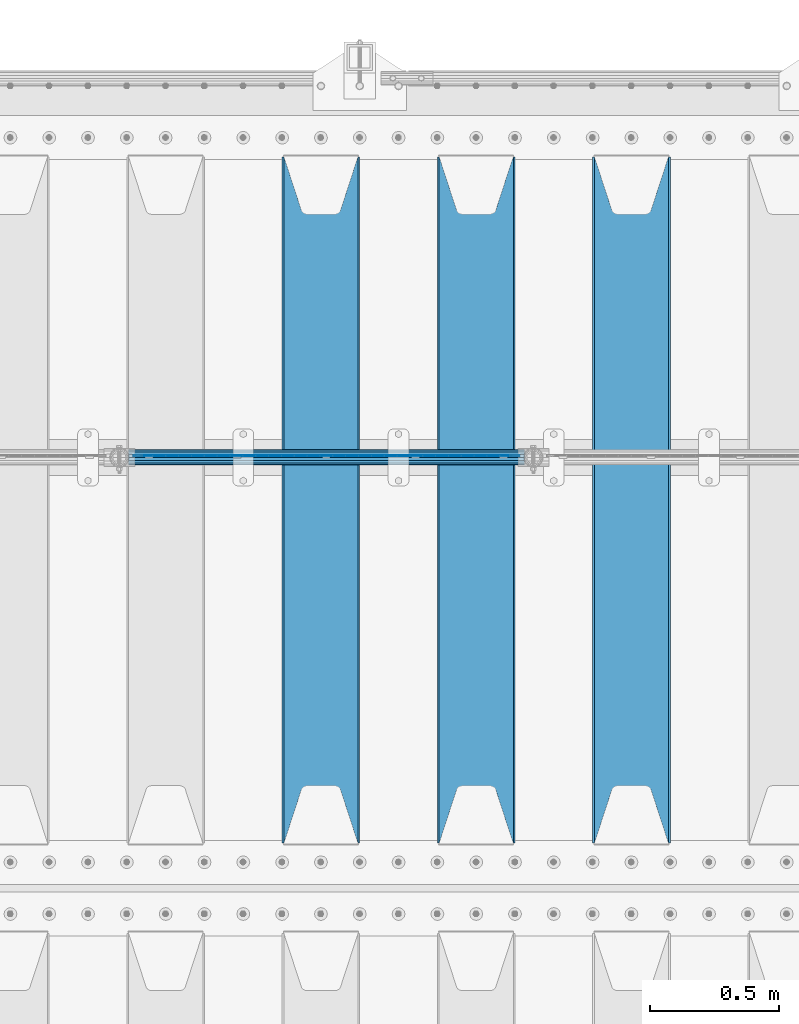
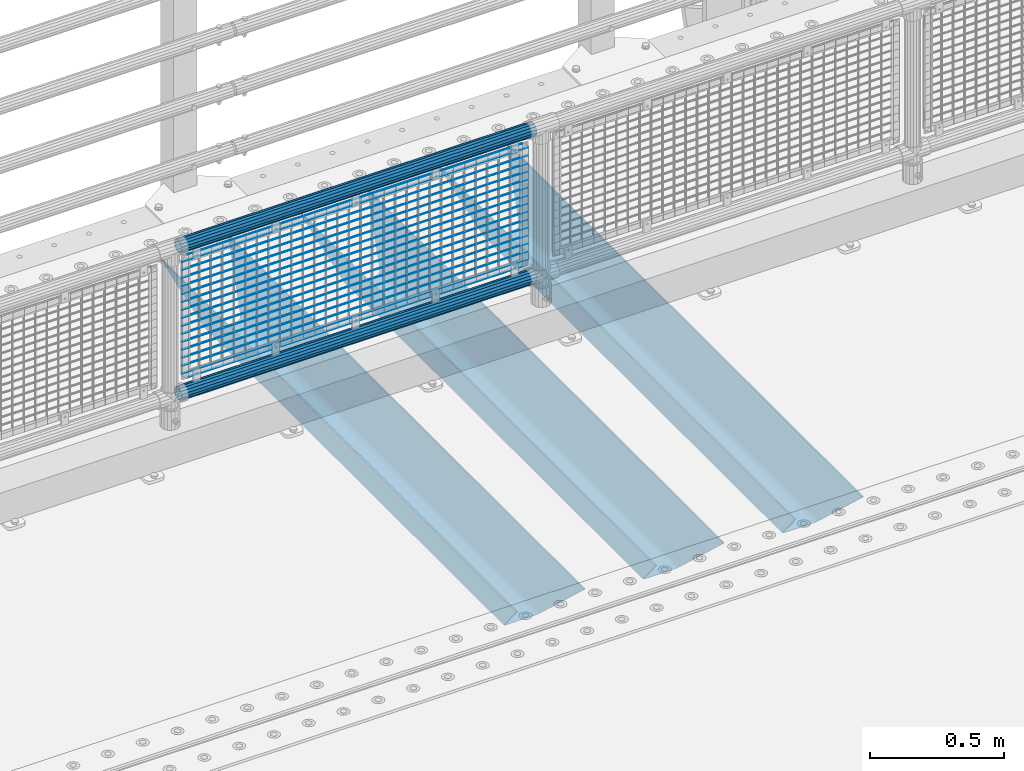
# One storey, part 126 of 247: 22 beams.
"""IFC2X3 building model written with IfcOpenShell, lengths in millimetres."""

from ifc_helpers import new_model, si_unit, frame, origin_with_axes, place, context, subcontext, project, spatial, faceted_brep, material, type_object, element, save


model = new_model("IFC2X3")

# Units and contexts
model_context = context("Model", 3, precision=1e-05, world=origin_with_axes())
body_context = subcontext(model_context, "Body", "Model", "MODEL_VIEW")
ifc_project = project(units=[si_unit("LENGTHUNIT", "METRE", prefix="MILLI"), si_unit("AREAUNIT", "SQUARE_METRE"), si_unit("VOLUMEUNIT", "CUBIC_METRE"), si_unit("MASSUNIT", "GRAM", prefix="KILO"), si_unit("TIMEUNIT", "SECOND"), si_unit("PLANEANGLEUNIT", "RADIAN"), si_unit("SOLIDANGLEUNIT", "STERADIAN"), si_unit("THERMODYNAMICTEMPERATUREUNIT", "DEGREE_CELSIUS"), si_unit("LUMINOUSINTENSITYUNIT", "LUMEN")], contexts=[model_context])

# Site, building, storey
site_placement = place(None, origin_with_axes())
site = spatial("IfcSite", under=ifc_project, at=site_placement, CompositionType="ELEMENT")
building_placement = place(site_placement, origin_with_axes())
building = spatial("IfcBuilding", under=site, at=building_placement, Name="Standard", CompositionType="ELEMENT")
storey_placement = place(building_placement, origin_with_axes())
storey = spatial("IfcBuildingStorey", under=building, at=storey_placement, Name="Undefined", CompositionType="ELEMENT", Elevation=0.0)

# Beams
ifc_material_1 = material(Name="STEEL/S355N")
beam_type_1 = type_object("IfcBeamType", PredefinedType="NOTDEFINED")
beam_1_placement = place(storey_placement, frame((10600.0, 6175.0, -115.0), z_axis=(0.0, 0.0, 1.0), x_axis=(0.0, 1.0, 0.0)))
element("IfcBeam", 1, at=beam_1_placement, inside=storey, type_object=beam_type_1, material=ifc_material_1, context=body_context, shape_type="Brep", body=[
    faceted_brep([(0.0, 150.0, 115.0), (0.0, 143.689999999999, 115.0), (2650.00000000297, 143.689999999999, 115.0), (2650.00000000297, 150.0, 115.0), (2650.00000000297, 142.059565218402, 110.0000000031), (2650.00000000297, 148.369565218403, 110.0000000031), (2441.90079219208, -80.1103600731112, -98.0992078077845), (2437.7588105432, -77.5672621345584, -102.241189456673), (2434.06523489746, -74.4080125315522, -105.934765102404), (2430.91086095089, -70.710272125576, -109.089139048974), (2428.37322971128, -66.5649389910068, -111.626770288588), (2426.51472138054, -62.0739139532889, -113.485278619323), (2425.38102192091, -57.3475956567672, -114.618978078955), (2424.99999999987, -52.5021667386536, -115.0), (2424.99999999987, 52.5021667386536, -115.0), (2425.38102192091, 57.3475956567672, -114.618978078955), (2426.51472138054, 62.0739139532889, -113.485278619323), (2428.37322971128, 66.5649389910068, -111.626770288588), (2430.91086095089, 70.710272125576, -109.089139048974), (2434.06523489746, 74.4080125315522, -105.934765102404), (2437.7588105432, 77.5672621345584, -102.241189456673), (2441.90079219208, 80.1103600731112, -98.0992078077846), (2446.38936140511, 81.9747917625791, -93.6106385947584), (2448.24948500409, 76.2713538057251, -91.7505149957729), (2444.62967112262, 74.76777986261, -95.3703288772456), (2441.28936334126, 72.7168944282894, -98.710636658607), (2438.31067330438, 70.1691124903846, -101.689326695487), (2435.76682334747, 67.1870637758839, -104.233176652398), (2433.72034654133, 63.8440531834895, -106.279653458539), (2432.22154950041, 60.222258798236, -107.778450499454), (2431.30727574265, 56.4107117849089, -108.692724257221), (2430.99999999987, 52.5031078186876, -109.0), (2430.99999999987, -52.5031078186876, -109.0), (2431.30727574265, -56.4107117849089, -108.692724257221), (2432.22154950041, -60.222258798236, -107.778450499454), (2433.72034654133, -63.8440531834895, -106.279653458539), (2435.76682334747, -67.1870637758839, -104.233176652398), (2438.31067330438, -70.1691124903846, -101.689326695487), (2441.28936334126, -72.7168944282894, -98.7106366586071), (2444.62967112262, -74.76777986261, -95.3703288772457), (2448.24948500409, -76.2713538057251, -91.7505149957729), (2650.00000000297, -142.059565218402, 110.0000000031), (2650.00000000297, -148.369565218403, 110.0000000031), (2446.38936140511, -81.9747917625791, -93.6106385947584), (2650.00000000297, -143.689999999999, 115.0), (2650.00000000297, -150.0, 115.0), (0.0, -143.689999999999, 115.0), (0.0, -150.0, 115.0), (0.0, -148.369565218261, 110.000000002663), (203.610638597422, -81.9747917625791, -93.6106385947584), (208.099207810448, -80.1103600731112, -98.0992078077845), (212.241189459336, -77.5672621345584, -102.241189456673), (215.934765105068, -74.4080125315522, -105.934765102404), (219.089139051637, -70.710272125576, -109.089139048974), (221.626770291251, -66.5649389910068, -111.626770288588), (223.485278621985, -62.0739139532889, -113.485278619323), (224.618978081617, -57.3475956567672, -114.618978078955), (225.000000002663, -52.5021667386536, -115.0), (225.000000002663, 52.5021667386536, -115.0), (224.618978081617, 57.3475956567672, -114.618978078955), (223.485278621985, 62.0739139532889, -113.485278619323), (221.626770291251, 66.5649389910068, -111.626770288588), (219.089139051637, 70.710272125576, -109.089139048974), (215.934765105068, 74.4080125315522, -105.934765102404), (212.241189459336, 77.5672621345584, -102.241189456673), (208.099207810448, 80.1103600731112, -98.0992078077846), (203.610638597422, 81.9747917625791, -93.6106385947584), (0.0, 148.369565218261, 110.000000002663), (0.0, 142.05956521826, 110.000000002663), (201.750514998436, 76.2713538057251, -91.7505149957729), (205.370328879908, 74.76777986261, -95.3703288772456), (208.710636661271, 72.7168944282894, -98.710636658607), (211.68932669815, 70.1691124903846, -101.689326695487), (214.233176655061, 67.1870637758839, -104.233176652398), (216.279653461202, 63.8440531834895, -106.279653458539), (217.778450502117, 60.222258798236, -107.778450499454), (218.692724259885, 56.4107117849089, -108.692724257221), (219.000000002663, 52.5031078186876, -109.0), (219.000000002663, -52.5031078186876, -109.0), (218.692724259885, -56.4107117849089, -108.692724257221), (217.778450502117, -60.222258798236, -107.778450499454), (216.279653461202, -63.8440531834895, -106.279653458539), (214.233176655061, -67.1870637758839, -104.233176652398), (211.68932669815, -70.1691124903846, -101.689326695487), (208.710636661271, -72.7168944282894, -98.7106366586071), (205.370328879908, -74.76777986261, -95.3703288772457), (201.750514998436, -76.2713538057251, -91.7505149957729), (0.0, -142.05956521826, 110.000000002663)], [[[0, 1, 2, 3]], [[3, 2, 4, 5]], [[6, 7, 8, 9, 10, 11, 12, 13, 14, 15, 16, 17, 18, 19, 20, 21, 22, 5, 4, 23, 24, 25, 26, 27, 28, 29, 30, 31, 32, 33, 34, 35, 36, 37, 38, 39, 40, 41, 42, 43]], [[44, 45, 42, 41]], [[46, 47, 45, 44]], [[43, 42, 45, 47, 48, 49]], [[6, 43, 49, 50]], [[7, 6, 50, 51]], [[8, 7, 51, 52]], [[9, 8, 52, 53]], [[10, 9, 53, 54]], [[11, 10, 54, 55]], [[12, 11, 55, 56]], [[13, 12, 56, 57]], [[14, 13, 57, 58]], [[15, 14, 58, 59]], [[16, 15, 59, 60]], [[17, 16, 60, 61]], [[18, 17, 61, 62]], [[19, 18, 62, 63]], [[20, 19, 63, 64]], [[21, 20, 64, 65]], [[22, 21, 65, 66]], [[0, 3, 5, 22, 66, 67]], [[1, 0, 67, 68]], [[23, 4, 2, 1, 68, 69]], [[24, 23, 69, 70]], [[25, 24, 70, 71]], [[26, 25, 71, 72]], [[27, 26, 72, 73]], [[28, 27, 73, 74]], [[29, 28, 74, 75]], [[30, 29, 75, 76]], [[31, 30, 76, 77]], [[32, 31, 77, 78]], [[33, 32, 78, 79]], [[34, 33, 79, 80]], [[35, 34, 80, 81]], [[36, 35, 81, 82]], [[37, 36, 82, 83]], [[38, 37, 83, 84]], [[39, 38, 84, 85]], [[40, 39, 85, 86]], [[46, 44, 41, 40, 86, 87]], [[47, 46, 87, 48]], [[86, 85, 84, 83, 82, 81, 80, 79, 78, 77, 76, 75, 74, 73, 72, 71, 70, 69, 68, 67, 66, 65, 64, 63, 62, 61, 60, 59, 58, 57, 56, 55, 54, 53, 52, 51, 50, 49, 48, 87]]]),
])
beam_2_placement = place(storey_placement, frame((10000.0, 6175.0, -115.0), z_axis=(0.0, 0.0, 1.0), x_axis=(0.0, 1.0, 0.0)))
element("IfcBeam", 2, at=beam_2_placement, inside=storey, type_object=beam_type_1, material=ifc_material_1, context=body_context, shape_type="Brep", body=[
    faceted_brep([(0.0, 150.0, 115.0), (0.0, 143.689999999999, 115.0), (2650.00000000297, 143.689999999999, 115.0), (2650.00000000297, 150.0, 115.0), (2650.00000000297, 142.059565218402, 110.0000000031), (2650.00000000297, 148.369565218403, 110.0000000031), (2441.90079219208, -80.1103600731112, -98.0992078077845), (2437.7588105432, -77.5672621345584, -102.241189456673), (2434.06523489746, -74.4080125315522, -105.934765102404), (2430.91086095089, -70.710272125576, -109.089139048974), (2428.37322971128, -66.5649389910068, -111.626770288588), (2426.51472138054, -62.0739139532889, -113.485278619323), (2425.38102192091, -57.3475956567672, -114.618978078955), (2424.99999999987, -52.5021667386536, -115.0), (2424.99999999987, 52.5021667386536, -115.0), (2425.38102192091, 57.3475956567672, -114.618978078955), (2426.51472138054, 62.0739139532889, -113.485278619323), (2428.37322971128, 66.5649389910068, -111.626770288588), (2430.91086095089, 70.710272125576, -109.089139048974), (2434.06523489746, 74.4080125315522, -105.934765102404), (2437.7588105432, 77.5672621345584, -102.241189456673), (2441.90079219208, 80.1103600731112, -98.0992078077846), (2446.38936140511, 81.9747917625791, -93.6106385947584), (2448.24948500409, 76.2713538057251, -91.7505149957729), (2444.62967112262, 74.76777986261, -95.3703288772456), (2441.28936334126, 72.7168944282894, -98.710636658607), (2438.31067330438, 70.1691124903846, -101.689326695487), (2435.76682334747, 67.1870637758839, -104.233176652398), (2433.72034654133, 63.8440531834895, -106.279653458539), (2432.22154950041, 60.222258798236, -107.778450499454), (2431.30727574265, 56.4107117849089, -108.692724257221), (2430.99999999987, 52.5031078186876, -109.0), (2430.99999999987, -52.5031078186876, -109.0), (2431.30727574265, -56.4107117849089, -108.692724257221), (2432.22154950041, -60.222258798236, -107.778450499454), (2433.72034654133, -63.8440531834895, -106.279653458539), (2435.76682334747, -67.1870637758839, -104.233176652398), (2438.31067330438, -70.1691124903846, -101.689326695487), (2441.28936334126, -72.7168944282894, -98.7106366586071), (2444.62967112262, -74.76777986261, -95.3703288772457), (2448.24948500409, -76.2713538057251, -91.7505149957729), (2650.00000000297, -142.059565218402, 110.0000000031), (2650.00000000297, -148.369565218403, 110.0000000031), (2446.38936140511, -81.9747917625791, -93.6106385947584), (2650.00000000297, -143.689999999999, 115.0), (2650.00000000297, -150.0, 115.0), (0.0, -143.689999999999, 115.0), (0.0, -150.0, 115.0), (0.0, -148.369565218261, 110.000000002663), (203.610638597422, -81.9747917625791, -93.6106385947584), (208.099207810448, -80.1103600731112, -98.0992078077845), (212.241189459336, -77.5672621345584, -102.241189456673), (215.934765105068, -74.4080125315522, -105.934765102404), (219.089139051637, -70.710272125576, -109.089139048974), (221.626770291251, -66.5649389910068, -111.626770288588), (223.485278621985, -62.0739139532889, -113.485278619323), (224.618978081617, -57.3475956567672, -114.618978078955), (225.000000002663, -52.5021667386536, -115.0), (225.000000002663, 52.5021667386536, -115.0), (224.618978081617, 57.3475956567672, -114.618978078955), (223.485278621985, 62.0739139532889, -113.485278619323), (221.626770291251, 66.5649389910068, -111.626770288588), (219.089139051637, 70.710272125576, -109.089139048974), (215.934765105068, 74.4080125315522, -105.934765102404), (212.241189459336, 77.5672621345584, -102.241189456673), (208.099207810448, 80.1103600731112, -98.0992078077846), (203.610638597422, 81.9747917625791, -93.6106385947584), (0.0, 148.369565218261, 110.000000002663), (0.0, 142.05956521826, 110.000000002663), (201.750514998436, 76.2713538057251, -91.7505149957729), (205.370328879908, 74.76777986261, -95.3703288772456), (208.710636661271, 72.7168944282894, -98.710636658607), (211.68932669815, 70.1691124903846, -101.689326695487), (214.233176655061, 67.1870637758839, -104.233176652398), (216.279653461202, 63.8440531834895, -106.279653458539), (217.778450502117, 60.222258798236, -107.778450499454), (218.692724259885, 56.4107117849089, -108.692724257221), (219.000000002663, 52.5031078186876, -109.0), (219.000000002663, -52.5031078186876, -109.0), (218.692724259885, -56.4107117849089, -108.692724257221), (217.778450502117, -60.222258798236, -107.778450499454), (216.279653461202, -63.8440531834895, -106.279653458539), (214.233176655061, -67.1870637758839, -104.233176652398), (211.68932669815, -70.1691124903846, -101.689326695487), (208.710636661271, -72.7168944282894, -98.7106366586071), (205.370328879908, -74.76777986261, -95.3703288772457), (201.750514998436, -76.2713538057251, -91.7505149957729), (0.0, -142.05956521826, 110.000000002663)], [[[0, 1, 2, 3]], [[3, 2, 4, 5]], [[6, 7, 8, 9, 10, 11, 12, 13, 14, 15, 16, 17, 18, 19, 20, 21, 22, 5, 4, 23, 24, 25, 26, 27, 28, 29, 30, 31, 32, 33, 34, 35, 36, 37, 38, 39, 40, 41, 42, 43]], [[44, 45, 42, 41]], [[46, 47, 45, 44]], [[43, 42, 45, 47, 48, 49]], [[6, 43, 49, 50]], [[7, 6, 50, 51]], [[8, 7, 51, 52]], [[9, 8, 52, 53]], [[10, 9, 53, 54]], [[11, 10, 54, 55]], [[12, 11, 55, 56]], [[13, 12, 56, 57]], [[14, 13, 57, 58]], [[15, 14, 58, 59]], [[16, 15, 59, 60]], [[17, 16, 60, 61]], [[18, 17, 61, 62]], [[19, 18, 62, 63]], [[20, 19, 63, 64]], [[21, 20, 64, 65]], [[22, 21, 65, 66]], [[0, 3, 5, 22, 66, 67]], [[1, 0, 67, 68]], [[23, 4, 2, 1, 68, 69]], [[24, 23, 69, 70]], [[25, 24, 70, 71]], [[26, 25, 71, 72]], [[27, 26, 72, 73]], [[28, 27, 73, 74]], [[29, 28, 74, 75]], [[30, 29, 75, 76]], [[31, 30, 76, 77]], [[32, 31, 77, 78]], [[33, 32, 78, 79]], [[34, 33, 79, 80]], [[35, 34, 80, 81]], [[36, 35, 81, 82]], [[37, 36, 82, 83]], [[38, 37, 83, 84]], [[39, 38, 84, 85]], [[40, 39, 85, 86]], [[46, 44, 41, 40, 86, 87]], [[47, 46, 87, 48]], [[86, 85, 84, 83, 82, 81, 80, 79, 78, 77, 76, 75, 74, 73, 72, 71, 70, 69, 68, 67, 66, 65, 64, 63, 62, 61, 60, 59, 58, 57, 56, 55, 54, 53, 52, 51, 50, 49, 48, 87]]]),
])
beam_3_placement = place(storey_placement, frame((9400.0, 6175.0, -115.0), z_axis=(0.0, 0.0, 1.0), x_axis=(0.0, 1.0, 0.0)))
element("IfcBeam", 3, at=beam_3_placement, inside=storey, type_object=beam_type_1, material=ifc_material_1, context=body_context, shape_type="Brep", body=[
    faceted_brep([(0.0, 150.0, 115.0), (0.0, 143.689999999999, 115.0), (2650.00000000297, 143.689999999999, 115.0), (2650.00000000297, 150.0, 115.0), (2650.00000000297, 142.059565218402, 110.0000000031), (2650.00000000297, 148.369565218403, 110.0000000031), (2441.90079219208, -80.1103600731112, -98.0992078077845), (2437.7588105432, -77.5672621345584, -102.241189456673), (2434.06523489746, -74.4080125315522, -105.934765102404), (2430.91086095089, -70.710272125576, -109.089139048974), (2428.37322971128, -66.5649389910068, -111.626770288588), (2426.51472138054, -62.0739139532889, -113.485278619323), (2425.38102192091, -57.3475956567672, -114.618978078955), (2424.99999999987, -52.5021667386536, -115.0), (2424.99999999987, 52.5021667386536, -115.0), (2425.38102192091, 57.3475956567672, -114.618978078955), (2426.51472138054, 62.0739139532889, -113.485278619323), (2428.37322971128, 66.5649389910068, -111.626770288588), (2430.91086095089, 70.710272125576, -109.089139048974), (2434.06523489746, 74.4080125315522, -105.934765102404), (2437.7588105432, 77.5672621345584, -102.241189456673), (2441.90079219208, 80.1103600731112, -98.0992078077846), (2446.38936140511, 81.9747917625791, -93.6106385947584), (2448.24948500409, 76.2713538057251, -91.7505149957729), (2444.62967112262, 74.76777986261, -95.3703288772456), (2441.28936334126, 72.7168944282894, -98.710636658607), (2438.31067330438, 70.1691124903846, -101.689326695487), (2435.76682334747, 67.1870637758839, -104.233176652398), (2433.72034654133, 63.8440531834895, -106.279653458539), (2432.22154950041, 60.222258798236, -107.778450499454), (2431.30727574265, 56.4107117849089, -108.692724257221), (2430.99999999987, 52.5031078186876, -109.0), (2430.99999999987, -52.5031078186876, -109.0), (2431.30727574265, -56.4107117849089, -108.692724257221), (2432.22154950041, -60.222258798236, -107.778450499454), (2433.72034654133, -63.8440531834895, -106.279653458539), (2435.76682334747, -67.1870637758839, -104.233176652398), (2438.31067330438, -70.1691124903846, -101.689326695487), (2441.28936334126, -72.7168944282894, -98.7106366586071), (2444.62967112262, -74.76777986261, -95.3703288772457), (2448.24948500409, -76.2713538057251, -91.7505149957729), (2650.00000000297, -142.059565218402, 110.0000000031), (2650.00000000297, -148.369565218403, 110.0000000031), (2446.38936140511, -81.9747917625791, -93.6106385947584), (2650.00000000297, -143.689999999999, 115.0), (2650.00000000297, -150.0, 115.0), (0.0, -143.689999999999, 115.0), (0.0, -150.0, 115.0), (0.0, -148.369565218261, 110.000000002663), (203.610638597422, -81.9747917625791, -93.6106385947584), (208.099207810448, -80.1103600731112, -98.0992078077845), (212.241189459336, -77.5672621345584, -102.241189456673), (215.934765105068, -74.4080125315522, -105.934765102404), (219.089139051637, -70.710272125576, -109.089139048974), (221.626770291251, -66.5649389910068, -111.626770288588), (223.485278621985, -62.0739139532889, -113.485278619323), (224.618978081617, -57.3475956567672, -114.618978078955), (225.000000002663, -52.5021667386536, -115.0), (225.000000002663, 52.5021667386536, -115.0), (224.618978081617, 57.3475956567672, -114.618978078955), (223.485278621985, 62.0739139532889, -113.485278619323), (221.626770291251, 66.5649389910068, -111.626770288588), (219.089139051637, 70.710272125576, -109.089139048974), (215.934765105068, 74.4080125315522, -105.934765102404), (212.241189459336, 77.5672621345584, -102.241189456673), (208.099207810448, 80.1103600731112, -98.0992078077846), (203.610638597422, 81.9747917625791, -93.6106385947584), (0.0, 148.369565218261, 110.000000002663), (0.0, 142.05956521826, 110.000000002663), (201.750514998436, 76.2713538057251, -91.7505149957729), (205.370328879908, 74.76777986261, -95.3703288772456), (208.710636661271, 72.7168944282894, -98.710636658607), (211.68932669815, 70.1691124903846, -101.689326695487), (214.233176655061, 67.1870637758839, -104.233176652398), (216.279653461202, 63.8440531834895, -106.279653458539), (217.778450502117, 60.222258798236, -107.778450499454), (218.692724259885, 56.4107117849089, -108.692724257221), (219.000000002663, 52.5031078186876, -109.0), (219.000000002663, -52.5031078186876, -109.0), (218.692724259885, -56.4107117849089, -108.692724257221), (217.778450502117, -60.222258798236, -107.778450499454), (216.279653461202, -63.8440531834895, -106.279653458539), (214.233176655061, -67.1870637758839, -104.233176652398), (211.68932669815, -70.1691124903846, -101.689326695487), (208.710636661271, -72.7168944282894, -98.7106366586071), (205.370328879908, -74.76777986261, -95.3703288772457), (201.750514998436, -76.2713538057251, -91.7505149957729), (0.0, -142.05956521826, 110.000000002663)], [[[0, 1, 2, 3]], [[3, 2, 4, 5]], [[6, 7, 8, 9, 10, 11, 12, 13, 14, 15, 16, 17, 18, 19, 20, 21, 22, 5, 4, 23, 24, 25, 26, 27, 28, 29, 30, 31, 32, 33, 34, 35, 36, 37, 38, 39, 40, 41, 42, 43]], [[44, 45, 42, 41]], [[46, 47, 45, 44]], [[43, 42, 45, 47, 48, 49]], [[6, 43, 49, 50]], [[7, 6, 50, 51]], [[8, 7, 51, 52]], [[9, 8, 52, 53]], [[10, 9, 53, 54]], [[11, 10, 54, 55]], [[12, 11, 55, 56]], [[13, 12, 56, 57]], [[14, 13, 57, 58]], [[15, 14, 58, 59]], [[16, 15, 59, 60]], [[17, 16, 60, 61]], [[18, 17, 61, 62]], [[19, 18, 62, 63]], [[20, 19, 63, 64]], [[21, 20, 64, 65]], [[22, 21, 65, 66]], [[0, 3, 5, 22, 66, 67]], [[1, 0, 67, 68]], [[23, 4, 2, 1, 68, 69]], [[24, 23, 69, 70]], [[25, 24, 70, 71]], [[26, 25, 71, 72]], [[27, 26, 72, 73]], [[28, 27, 73, 74]], [[29, 28, 74, 75]], [[30, 29, 75, 76]], [[31, 30, 76, 77]], [[32, 31, 77, 78]], [[33, 32, 78, 79]], [[34, 33, 79, 80]], [[35, 34, 80, 81]], [[36, 35, 81, 82]], [[37, 36, 82, 83]], [[38, 37, 83, 84]], [[39, 38, 84, 85]], [[40, 39, 85, 86]], [[46, 44, 41, 40, 86, 87]], [[47, 46, 87, 48]], [[86, 85, 84, 83, 82, 81, 80, 79, 78, 77, 76, 75, 74, 73, 72, 71, 70, 69, 68, 67, 66, 65, 64, 63, 62, 61, 60, 59, 58, 57, 56, 55, 54, 53, 52, 51, 50, 49, 48, 87]]]),
])
ifc_material_2 = material()
beam_type_2 = type_object("IfcBeamType", PredefinedType="NOTDEFINED")
beam_4_placement = place(storey_placement, frame((8655.85000000001, 7664.5, 298.170000000004), z_axis=(0.0, 0.0, 1.0), x_axis=(1.0, 0.0, 0.0)))
element("IfcBeam", 4, at=beam_4_placement, inside=storey, type_object=beam_type_2, material=ifc_material_2, context=body_context, shape_type="Brep", body=[
    faceted_brep([(0.0, -25.3500000000004, 0.0), (0.0, -23.4203461491616, 9.70102501045585), (1530.0, -23.4203461491616, 9.70102501045506), (1530.0, -25.3500000000004, 0.0), (0.0, -17.9251569030794, 17.9251569030785), (1530.0, -17.9251569030794, 17.925156903079), (0.0, -9.70102501045494, 23.4203461491616), (1530.0, -9.70102501045494, 23.4203461491611), (0.0, 0.0, 25.3500000000004), (1530.0, 0.0, 25.35), (0.0, 9.70102501045494, 23.4203461491616), (1530.0, 9.70102501045494, 23.4203461491611), (0.0, 17.9251569030794, 17.9251569030785), (1530.0, 17.9251569030794, 17.925156903079), (0.0, 23.4203461491616, 9.70102501045585), (1530.0, 23.4203461491616, 9.70102501045506), (0.0, 25.3500000000004, 0.0), (1530.0, 25.3500000000004, 0.0), (0.0, 23.4203461491616, -9.70102501045585), (1530.0, 23.4203461491616, -9.70102501045506), (0.0, 17.9251569030794, -17.9251569030785), (1530.0, 17.9251569030794, -17.925156903079), (0.0, 9.70102501045494, -23.4203461491616), (1530.0, 9.70102501045494, -23.4203461491611), (0.0, 0.0, -25.3500000000004), (1530.0, 0.0, -25.35), (0.0, -9.70102501045494, -23.4203461491616), (1530.0, -9.70102501045494, -23.4203461491611), (0.0, -17.9251569030794, -17.9251569030785), (1530.0, -17.9251569030794, -17.925156903079), (0.0, -23.4203461491616, -9.70102501045585), (1530.0, -23.4203461491616, -9.70102501045506), (0.0, -30.1499999999996, 0.0), (0.0, -27.8549679052148, -11.5379054858076), (1530.0, -27.8549679052148, -11.5379054858075), (1530.0, -30.1499999999996, 0.0), (0.0, -21.3192694527743, -21.3192694527752), (1530.0, -21.3192694527743, -21.3192694527744), (0.0, -11.5379054858076, -27.8549679052157), (1530.0, -11.5379054858076, -27.8549679052153), (0.0, 0.0, -30.1499999999996), (1530.0, 0.0, -30.15), (0.0, 11.5379054858076, -27.8549679052157), (1530.0, 11.5379054858076, -27.8549679052153), (0.0, 21.3192694527743, -21.3192694527752), (1530.0, 21.3192694527743, -21.3192694527744), (0.0, 27.8549679052157, -11.5379054858076), (1530.0, 27.8549679052157, -11.5379054858074), (0.0, 30.1499999999996, 0.0), (1530.0, 30.1499999999996, 0.0), (0.0, 27.8549679052157, 11.5379054858076), (1530.0, 27.8549679052157, 11.5379054858074), (0.0, 21.3192694527743, 21.3192694527752), (1530.0, 21.3192694527743, 21.3192694527744), (0.0, 11.5379054858076, 27.8549679052157), (1530.0, 11.5379054858076, 27.8549679052153), (0.0, 0.0, 30.1499999999996), (1530.0, 0.0, 30.15), (0.0, -11.5379054858076, 27.8549679052157), (1530.0, -11.5379054858076, 27.8549679052153), (0.0, -21.3192694527743, 21.3192694527752), (1530.0, -21.3192694527743, 21.3192694527744), (0.0, -27.8549679052157, 11.5379054858076), (1530.0, -27.8549679052157, 11.5379054858074)], [[[0, 1, 2, 3]], [[1, 4, 5, 2]], [[4, 6, 7, 5]], [[6, 8, 9, 7]], [[8, 10, 11, 9]], [[10, 12, 13, 11]], [[12, 14, 15, 13]], [[14, 16, 17, 15]], [[16, 18, 19, 17]], [[18, 20, 21, 19]], [[20, 22, 23, 21]], [[22, 24, 25, 23]], [[24, 26, 27, 25]], [[26, 28, 29, 27]], [[28, 30, 31, 29]], [[30, 0, 3, 31]], [[32, 33, 34, 35]], [[33, 36, 37, 34]], [[36, 38, 39, 37]], [[38, 40, 41, 39]], [[40, 42, 43, 41]], [[42, 44, 45, 43]], [[44, 46, 47, 45]], [[46, 48, 49, 47]], [[48, 50, 51, 49]], [[50, 52, 53, 51]], [[52, 54, 55, 53]], [[54, 56, 57, 55]], [[56, 58, 59, 57]], [[58, 60, 61, 59]], [[60, 62, 63, 61]], [[62, 32, 35, 63]], [[37, 39, 41, 43, 45, 47, 49, 51, 53, 55, 57, 59, 61, 63, 35, 34], [5, 7, 9, 11, 13, 15, 17, 19, 21, 23, 25, 27, 29, 31, 3, 2]], [[62, 60, 58, 56, 54, 52, 50, 48, 46, 44, 42, 40, 38, 36, 33, 32], [30, 28, 26, 24, 22, 20, 18, 16, 14, 12, 10, 8, 6, 4, 1, 0]]]),
])
beam_5_placement = place(storey_placement, frame((8655.85, 7664.5, 969.850000000003), z_axis=(0.0, 0.0, 1.0), x_axis=(1.0, 0.0, 0.0)))
element("IfcBeam", 5, at=beam_5_placement, inside=storey, type_object=beam_type_2, material=ifc_material_2, context=body_context, shape_type="Brep", body=[
    faceted_brep([(0.0, -25.3500000000004, 0.0), (0.0, -23.4203461491616, 9.70102501045585), (1530.0, -23.4203461491616, 9.70102501045506), (1530.0, -25.3500000000004, 0.0), (0.0, -17.9251569030794, 17.9251569030785), (1530.0, -17.9251569030794, 17.925156903079), (0.0, -9.70102501045494, 23.4203461491616), (1530.0, -9.70102501045494, 23.4203461491611), (0.0, 0.0, 25.3500000000004), (1530.0, 0.0, 25.35), (0.0, 9.70102501045494, 23.4203461491616), (1530.0, 9.70102501045494, 23.4203461491611), (0.0, 17.9251569030794, 17.9251569030785), (1530.0, 17.9251569030794, 17.925156903079), (0.0, 23.4203461491616, 9.70102501045585), (1530.0, 23.4203461491616, 9.70102501045506), (0.0, 25.3500000000004, 0.0), (1530.0, 25.3500000000004, 0.0), (0.0, 23.4203461491616, -9.70102501045585), (1530.0, 23.4203461491616, -9.70102501045506), (0.0, 17.9251569030794, -17.9251569030785), (1530.0, 17.9251569030794, -17.925156903079), (0.0, 9.70102501045494, -23.4203461491616), (1530.0, 9.70102501045494, -23.4203461491611), (0.0, 0.0, -25.3500000000004), (1530.0, 0.0, -25.35), (0.0, -9.70102501045494, -23.4203461491616), (1530.0, -9.70102501045494, -23.4203461491611), (0.0, -17.9251569030794, -17.9251569030785), (1530.0, -17.9251569030794, -17.925156903079), (0.0, -23.4203461491616, -9.70102501045585), (1530.0, -23.4203461491616, -9.70102501045506), (0.0, -30.1499999999996, 0.0), (0.0, -27.8549679052148, -11.5379054858076), (1530.0, -27.8549679052148, -11.5379054858075), (1530.0, -30.1499999999996, 0.0), (0.0, -21.3192694527743, -21.3192694527752), (1530.0, -21.3192694527743, -21.3192694527744), (0.0, -11.5379054858076, -27.8549679052157), (1530.0, -11.5379054858076, -27.8549679052153), (0.0, 0.0, -30.1499999999996), (1530.0, 0.0, -30.15), (0.0, 11.5379054858076, -27.8549679052157), (1530.0, 11.5379054858076, -27.8549679052153), (0.0, 21.3192694527743, -21.3192694527752), (1530.0, 21.3192694527743, -21.3192694527744), (0.0, 27.8549679052157, -11.5379054858076), (1530.0, 27.8549679052157, -11.5379054858074), (0.0, 30.1499999999996, 0.0), (1530.0, 30.1499999999996, 0.0), (0.0, 27.8549679052157, 11.5379054858076), (1530.0, 27.8549679052157, 11.5379054858074), (0.0, 21.3192694527743, 21.3192694527752), (1530.0, 21.3192694527743, 21.3192694527744), (0.0, 11.5379054858076, 27.8549679052157), (1530.0, 11.5379054858076, 27.8549679052153), (0.0, 0.0, 30.1499999999996), (1530.0, 0.0, 30.15), (0.0, -11.5379054858076, 27.8549679052157), (1530.0, -11.5379054858076, 27.8549679052153), (0.0, -21.3192694527743, 21.3192694527752), (1530.0, -21.3192694527743, 21.3192694527744), (0.0, -27.8549679052157, 11.5379054858076), (1530.0, -27.8549679052157, 11.5379054858074)], [[[0, 1, 2, 3]], [[1, 4, 5, 2]], [[4, 6, 7, 5]], [[6, 8, 9, 7]], [[8, 10, 11, 9]], [[10, 12, 13, 11]], [[12, 14, 15, 13]], [[14, 16, 17, 15]], [[16, 18, 19, 17]], [[18, 20, 21, 19]], [[20, 22, 23, 21]], [[22, 24, 25, 23]], [[24, 26, 27, 25]], [[26, 28, 29, 27]], [[28, 30, 31, 29]], [[30, 0, 3, 31]], [[32, 33, 34, 35]], [[33, 36, 37, 34]], [[36, 38, 39, 37]], [[38, 40, 41, 39]], [[40, 42, 43, 41]], [[42, 44, 45, 43]], [[44, 46, 47, 45]], [[46, 48, 49, 47]], [[48, 50, 51, 49]], [[50, 52, 53, 51]], [[52, 54, 55, 53]], [[54, 56, 57, 55]], [[56, 58, 59, 57]], [[58, 60, 61, 59]], [[60, 62, 63, 61]], [[62, 32, 35, 63]], [[37, 39, 41, 43, 45, 47, 49, 51, 53, 55, 57, 59, 61, 63, 35, 34], [5, 7, 9, 11, 13, 15, 17, 19, 21, 23, 25, 27, 29, 31, 3, 2]], [[62, 60, 58, 56, 54, 52, 50, 48, 46, 44, 42, 40, 38, 36, 33, 32], [30, 28, 26, 24, 22, 20, 18, 16, 14, 12, 10, 8, 6, 4, 1, 0]]]),
])
ifc_material_3 = material(Name="Misc_Undefined")
beam_type_3 = type_object("IfcBeamType", Name="D3", PredefinedType="NOTDEFINED")
for number, where, z_axis, x_axis in (
    (6, (8676.0, 7670.5, 851.597000000003), (0.0, 0.0, 1.0), (1.0, 0.0, 0.0)),
    (7, (8676.0, 7670.5, 669.452000000003), (0.0, 0.0, 1.0), (1.0, 0.0, 0.0)),
    (8, (8676.0, 7670.5, 523.736000000003), (0.0, 0.0, 1.0), (1.0, 0.0, 0.0)),
    (9, (8676.0, 7670.5, 487.307000000003), (0.0, 0.0, 1.0), (1.0, 0.0, 0.0)),
    (10, (8676.0, 7670.5, 705.881000000003), (0.0, 0.0, 1.0), (1.0, 0.0, 0.0)),
    (11, (8676.0, 7670.5, 596.594000000003), (0.0, 0.0, 1.0), (1.0, 0.0, 0.0)),
    (12, (8676.0, 7670.5, 450.878000000003), (0.0, 0.0, 1.0), (1.0, 0.0, 0.0)),
    (13, (8676.0, 7670.5, 815.168000000003), (0.0, 0.0, 1.0), (1.0, 0.0, 0.0)),
    (14, (8676.0, 7670.5, 888.026000000003), (0.0, 0.0, 1.0), (1.0, 0.0, 0.0)),
    (15, (8676.0, 7670.5, 778.739000000003), (0.0, 0.0, 1.0), (1.0, 0.0, 0.0)),
    (16, (8676.0, 7670.5, 742.310000000003), (0.0, 0.0, 1.0), (1.0, 0.0, 0.0)),
    (17, (8676.0, 7670.5, 633.023000000003), (0.0, 0.0, 1.0), (1.0, 0.0, 0.0)),
    (18, (8676.0, 7670.5, 560.165000000003), (0.0, 0.0, 1.0), (1.0, 0.0, 0.0)),
    (19, (8676.0, 7670.5, 414.449000000003), (0.0, 0.0, 1.0), (1.0, 0.0, 0.0)),
):
    element("IfcBeam", number, at=place(storey_placement, frame(where, z_axis=z_axis, x_axis=x_axis)), inside=storey, type_object=beam_type_3, material=ifc_material_3, ObjectType="D3", context=body_context, shape_type="Brep", body=[
        faceted_brep([(1.81898940354586e-12, -1.5, -5.6843418860808e-14), (0.0, -0.75, -1.29903810567703), (1490.0, -0.75, -1.29903810567669), (1490.0, -1.5, 0.0), (0.0, 0.75, -1.29903810567703), (1490.0, 0.75, -1.29903810567669), (1.81898940354586e-12, 1.5, -5.6843418860808e-14), (1490.0, 1.5, 0.0), (0.0, 0.75, 1.29903810567703), (1490.0, 0.75, 1.29903810567669), (0.0, -0.75, 1.29903810567703), (1490.0, -0.75, 1.29903810567669)], [[[0, 1, 2, 3]], [[1, 4, 5, 2]], [[4, 6, 7, 5]], [[6, 8, 9, 7]], [[8, 10, 11, 9]], [[10, 0, 3, 11]], [[5, 7, 9, 11, 3, 2]], [[10, 8, 6, 4, 1, 0]]]),
    ])
beam_6_placement = place(storey_placement, frame((8701.0, 7670.5, 353.020000000003), z_axis=(0.0, 0.0, 1.0), x_axis=(1.0, 0.0, 0.0)))
element("IfcBeam", 20, at=beam_6_placement, inside=storey, type_object=beam_type_3, material=ifc_material_3, ObjectType="D3", context=body_context, shape_type="Brep", body=[
    faceted_brep([(1.81898940354586e-12, -1.5, -5.6843418860808e-14), (0.0, -0.75, -1.29903810567703), (1440.0, -0.75, -1.29903810567669), (1440.0, -1.5, 0.0), (0.0, 0.75, -1.29903810567703), (1440.0, 0.75, -1.29903810567663), (1.81898940354586e-12, 1.5, -5.6843418860808e-14), (1440.0, 1.5, 0.0), (0.0, 0.75, 1.29903810567703), (1440.0, 0.75, 1.29903810567669), (0.0, -0.75, 1.29903810567703), (1440.0, -0.75, 1.29903810567669)], [[[0, 1, 2, 3]], [[1, 4, 5, 2]], [[4, 6, 7, 5]], [[6, 8, 9, 7]], [[8, 10, 11, 9]], [[10, 0, 3, 11]], [[5, 7, 9, 11, 3, 2]], [[10, 8, 6, 4, 1, 0]]]),
])
beam_7_placement = place(storey_placement, frame((8676.0, 7670.5, 378.020000000003), z_axis=(0.0, 0.0, 1.0), x_axis=(1.0, 0.0, 0.0)))
element("IfcBeam", 21, at=beam_7_placement, inside=storey, type_object=beam_type_3, material=ifc_material_3, ObjectType="D3", context=body_context, shape_type="Brep", body=[
    faceted_brep([(1.81898940354586e-12, -1.5, -5.6843418860808e-14), (0.0, -0.75, -1.29903810567703), (1490.0, -0.75, -1.29903810567669), (1490.0, -1.5, 0.0), (0.0, 0.75, -1.29903810567703), (1490.0, 0.75, -1.29903810567669), (1.81898940354586e-12, 1.5, -5.6843418860808e-14), (1490.0, 1.5, 0.0), (0.0, 0.75, 1.29903810567703), (1490.0, 0.75, 1.29903810567669), (0.0, -0.75, 1.29903810567703), (1490.0, -0.75, 1.29903810567669)], [[[0, 1, 2, 3]], [[1, 4, 5, 2]], [[4, 6, 7, 5]], [[6, 8, 9, 7]], [[8, 10, 11, 9]], [[10, 0, 3, 11]], [[5, 7, 9, 11, 3, 2]], [[10, 8, 6, 4, 1, 0]]]),
])
beam_8_placement = place(storey_placement, frame((8701.0, 7670.5, 913.020000000003), z_axis=(0.0, 0.0, 1.0), x_axis=(1.0, 0.0, 0.0)))
element("IfcBeam", 22, at=beam_8_placement, inside=storey, type_object=beam_type_3, material=ifc_material_3, ObjectType="D3", context=body_context, shape_type="Brep", body=[
    faceted_brep([(1.81898940354586e-12, -1.5, -5.6843418860808e-14), (0.0, -0.75, -1.29903810567703), (1440.0, -0.75, -1.29903810567669), (1440.0, -1.5, 0.0), (0.0, 0.75, -1.29903810567703), (1440.0, 0.75, -1.29903810567663), (1.81898940354586e-12, 1.5, -5.6843418860808e-14), (1440.0, 1.5, 0.0), (0.0, 0.75, 1.29903810567703), (1440.0, 0.75, 1.29903810567669), (0.0, -0.75, 1.29903810567703), (1440.0, -0.75, 1.29903810567669)], [[[0, 1, 2, 3]], [[1, 4, 5, 2]], [[4, 6, 7, 5]], [[6, 8, 9, 7]], [[8, 10, 11, 9]], [[10, 0, 3, 11]], [[5, 7, 9, 11, 3, 2]], [[10, 8, 6, 4, 1, 0]]]),
])

save(model, "model.ifc")
